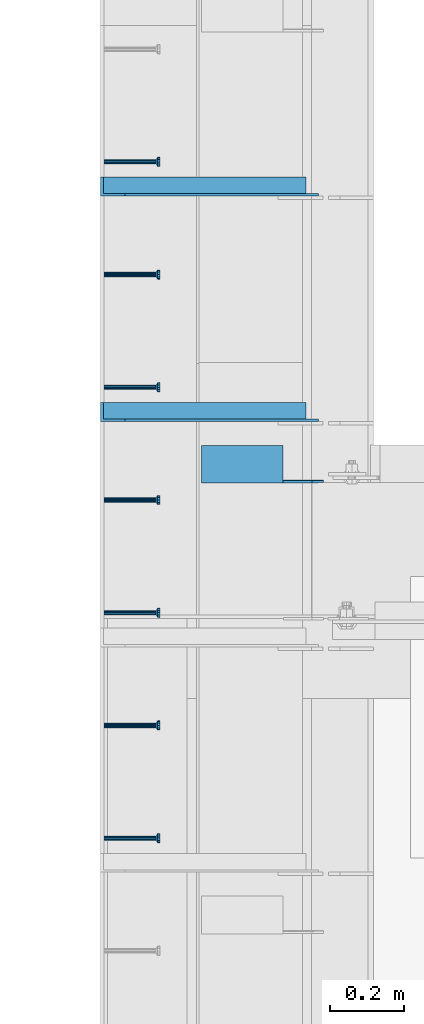
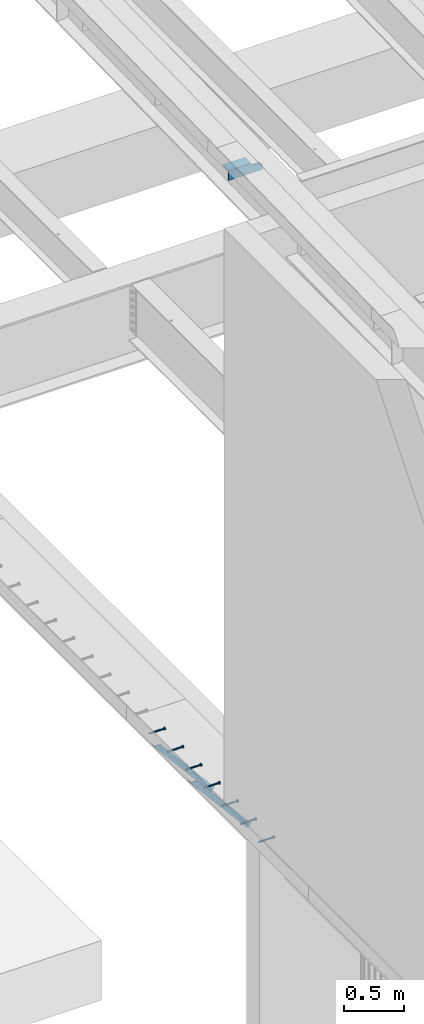
# One storey, part 1276 of 1763: 8 beams, 2 members, 9 elements without a shape of their own.
"""IFC2X3 building model written with IfcOpenShell, lengths in millimetres."""

from ifc_helpers import new_model, si_unit, frame, origin_with_axes, place, context, subcontext, project, spatial, faceted_brep, material, type_object, element, aggregate, save


model = new_model("IFC2X3")

# Units and contexts
model_context = context("Model", 3, precision=1e-05, world=origin_with_axes())
body_context = subcontext(model_context, "Body", "Model", "MODEL_VIEW")
ifc_project = project(units=[si_unit("LENGTHUNIT", "METRE", prefix="MILLI"), si_unit("AREAUNIT", "SQUARE_METRE"), si_unit("VOLUMEUNIT", "CUBIC_METRE"), si_unit("MASSUNIT", "GRAM", prefix="KILO"), si_unit("TIMEUNIT", "SECOND"), si_unit("PLANEANGLEUNIT", "RADIAN"), si_unit("SOLIDANGLEUNIT", "STERADIAN"), si_unit("THERMODYNAMICTEMPERATUREUNIT", "DEGREE_CELSIUS"), si_unit("LUMINOUSINTENSITYUNIT", "LUMEN")], contexts=[model_context])

# Site, building, storey
site_placement = place(None, origin_with_axes())
site = spatial("IfcSite", under=ifc_project, at=site_placement, CompositionType="ELEMENT")
building_placement = place(site_placement, origin_with_axes())
building = spatial("IfcBuilding", under=site, at=building_placement, Name="Undefined", CompositionType="ELEMENT")
storey_placement = place(building_placement, origin_with_axes())
storey = spatial("IfcBuildingStorey", under=building, at=storey_placement, Name="Undefined", CompositionType="ELEMENT", Elevation=0.0)

# Assembly, beam
assembly_1_placement = place(storey_placement, origin_with_axes())
assembly_1 = element("IfcElementAssembly", 1, at=assembly_1_placement, inside=storey, Name="HEADED STUD ANCHOR", AssemblyPlace="NOTDEFINED", PredefinedType="RIGID_FRAME")
ifc_material_1 = material(Name="STEEL/A108")
beam_type_1 = type_object("IfcBeamType", PredefinedType="NOTDEFINED")
beam_1_placement = place(assembly_1_placement, frame((-87975.5122736983, 36972.8750061035, 5268.91250001202), z_axis=(0.0, 0.0, -1.0), x_axis=(1.0, 0.0, 0.0)))
beam_1 = element("IfcBeam", 2, at=beam_1_placement, type_object=beam_type_1, material=ifc_material_1, Name="HEADED STUD ANCHOR", context=body_context, shape_type="Brep", body=[
    faceted_brep([(0.0, -3.1800000667572, 5.5), (0.0, -5.5, 3.1800000667572), (141.732000000002, -5.5, 3.1800000667572), (141.732000000002, -3.1800000667572, 5.5), (0.0, -6.34999999999491, 1.45519152283669e-11), (141.732000000002, -6.34999990463257, 0.0), (0.0, -5.5, -3.1800000667572), (141.732000000002, -5.5, -3.1800000667572), (0.0, -3.1800000667572, -5.5), (141.732000000002, -3.1800000667572, -5.5), (0.0, 0.0, -6.34999990463257), (141.732000000002, 0.0, -6.34999990463257), (0.0, 3.1800000667572, -5.5), (141.732000000002, 3.1800000667572, -5.5), (0.0, 5.5, -3.1800000667572), (141.732000000002, 5.5, -3.1800000667572), (0.0, 6.34999999999491, -2.91038304567337e-11), (141.732000000002, 6.34999990463257, 0.0), (0.0, 5.5, 3.1800000667572), (141.732000000002, 5.5, 3.1800000667572), (0.0, 3.1800000667572, 5.5), (141.732000000002, 3.1800000667572, 5.5), (0.0, 0.0, 6.34999990463257), (141.732000000002, 0.0, 6.34999990463257), (144.780000000001, -10.9899997711182, 6.34999990463257), (144.780000000001, -6.34000015258789, 10.9899997711182), (144.780000000001, -12.6999998092651, 0.0), (144.780000000001, -10.9899997711182, -6.34999990463257), (144.780000000001, -6.34000015258789, -10.9899997711182), (144.780000000001, 0.0, -12.6899995803833), (144.780000000001, 6.34000015258789, -10.9899997711182), (144.780000000001, 10.9899997711182, -6.34999990463257), (144.780000000001, 12.6999998092651, 0.0), (144.780000000001, 10.9899997711182, 6.34999990463257), (144.780000000001, 6.34000015258789, 10.9899997711182), (144.780000000001, 0.0, 12.6899995803833), (152.400000000001, -10.9899997711182, 6.34999990463257), (152.400000000001, -6.34000015258789, 10.9899997711182), (152.400000000001, -12.6999998092651, 0.0), (152.400000000001, -10.9899997711182, -6.34999990463257), (152.400000000001, -6.34000015258789, -10.9899997711182), (152.400000000001, 0.0, -12.6899995803833), (152.400000000001, 6.34000015258789, -10.9899997711182), (152.400000000001, 10.9899997711182, -6.34999990463257), (152.400000000001, 12.6999998092651, 0.0), (152.400000000001, 10.9899997711182, 6.34999990463257), (152.400000000001, 6.34000015258789, 10.9899997711182), (152.400000000001, 0.0, 12.6899995803833)], [[[0, 1, 2, 3]], [[1, 4, 5, 2]], [[4, 6, 7, 5]], [[6, 8, 9, 7]], [[8, 10, 11, 9]], [[10, 12, 13, 11]], [[12, 14, 15, 13]], [[14, 16, 17, 15]], [[16, 18, 19, 17]], [[18, 20, 21, 19]], [[20, 22, 23, 21]], [[22, 0, 3, 23]], [[22, 20, 18, 16, 14, 12, 10, 8, 6, 4, 1, 0]], [[3, 2, 24, 25]], [[2, 5, 26, 24]], [[5, 7, 27, 26]], [[7, 9, 28, 27]], [[9, 11, 29, 28]], [[11, 13, 30, 29]], [[13, 15, 31, 30]], [[15, 17, 32, 31]], [[17, 19, 33, 32]], [[19, 21, 34, 33]], [[21, 23, 35, 34]], [[23, 3, 25, 35]], [[25, 24, 36, 37]], [[24, 26, 38, 36]], [[26, 27, 39, 38]], [[27, 28, 40, 39]], [[28, 29, 41, 40]], [[29, 30, 42, 41]], [[30, 31, 43, 42]], [[31, 32, 44, 43]], [[32, 33, 45, 44]], [[33, 34, 46, 45]], [[34, 35, 47, 46]], [[35, 25, 37, 47]], [[38, 39, 40, 41, 42, 43, 44, 45, 46, 47, 37, 36]]]),
])
aggregate(assembly_1, [beam_1])

assembly_2_placement = place(storey_placement, origin_with_axes())
assembly_2 = element("IfcElementAssembly", 3, at=assembly_2_placement, inside=storey, Name="HEADED STUD ANCHOR", AssemblyPlace="NOTDEFINED", PredefinedType="RIGID_FRAME")
beam_2_placement = place(assembly_2_placement, frame((-87975.5122736983, 37277.6750061035, 5268.91250001202), z_axis=(0.0, 0.0, -1.0), x_axis=(1.0, 0.0, 0.0)))
beam_2 = element("IfcBeam", 4, at=beam_2_placement, type_object=beam_type_1, material=ifc_material_1, Name="HEADED STUD ANCHOR", context=body_context, shape_type="Brep", body=[
    faceted_brep([(0.0, -3.1800000667572, 5.5), (0.0, -5.5, 3.1800000667572), (141.732000000002, -5.5, 3.1800000667572), (141.732000000002, -3.1800000667572, 5.5), (0.0, -6.34999999999491, 1.45519152283669e-11), (141.732000000002, -6.34999990463257, 0.0), (0.0, -5.5, -3.1800000667572), (141.732000000002, -5.5, -3.1800000667572), (0.0, -3.1800000667572, -5.5), (141.732000000002, -3.1800000667572, -5.5), (0.0, 0.0, -6.34999990463257), (141.732000000002, 0.0, -6.34999990463257), (0.0, 3.1800000667572, -5.5), (141.732000000002, 3.1800000667572, -5.5), (0.0, 5.5, -3.1800000667572), (141.732000000002, 5.5, -3.1800000667572), (0.0, 6.34999999999491, -2.91038304567337e-11), (141.732000000002, 6.34999990463257, 0.0), (0.0, 5.5, 3.1800000667572), (141.732000000002, 5.5, 3.1800000667572), (0.0, 3.1800000667572, 5.5), (141.732000000002, 3.1800000667572, 5.5), (0.0, 0.0, 6.34999990463257), (141.732000000002, 0.0, 6.34999990463257), (144.780000000001, -10.9899997711182, 6.34999990463257), (144.780000000001, -6.34000015258789, 10.9899997711182), (144.780000000001, -12.6999998092651, 0.0), (144.780000000001, -10.9899997711182, -6.34999990463257), (144.780000000001, -6.34000015258789, -10.9899997711182), (144.780000000001, 0.0, -12.6899995803833), (144.780000000001, 6.34000015258789, -10.9899997711182), (144.780000000001, 10.9899997711182, -6.34999990463257), (144.780000000001, 12.6999998092651, 0.0), (144.780000000001, 10.9899997711182, 6.34999990463257), (144.780000000001, 6.34000015258789, 10.9899997711182), (144.780000000001, 0.0, 12.6899995803833), (152.400000000001, -10.9899997711182, 6.34999990463257), (152.400000000001, -6.34000015258789, 10.9899997711182), (152.400000000001, -12.6999998092651, 0.0), (152.400000000001, -10.9899997711182, -6.34999990463257), (152.400000000001, -6.34000015258789, -10.9899997711182), (152.400000000001, 0.0, -12.6899995803833), (152.400000000001, 6.34000015258789, -10.9899997711182), (152.400000000001, 10.9899997711182, -6.34999990463257), (152.400000000001, 12.6999998092651, 0.0), (152.400000000001, 10.9899997711182, 6.34999990463257), (152.400000000001, 6.34000015258789, 10.9899997711182), (152.400000000001, 0.0, 12.6899995803833)], [[[0, 1, 2, 3]], [[1, 4, 5, 2]], [[4, 6, 7, 5]], [[6, 8, 9, 7]], [[8, 10, 11, 9]], [[10, 12, 13, 11]], [[12, 14, 15, 13]], [[14, 16, 17, 15]], [[16, 18, 19, 17]], [[18, 20, 21, 19]], [[20, 22, 23, 21]], [[22, 0, 3, 23]], [[22, 20, 18, 16, 14, 12, 10, 8, 6, 4, 1, 0]], [[3, 2, 24, 25]], [[2, 5, 26, 24]], [[5, 7, 27, 26]], [[7, 9, 28, 27]], [[9, 11, 29, 28]], [[11, 13, 30, 29]], [[13, 15, 31, 30]], [[15, 17, 32, 31]], [[17, 19, 33, 32]], [[19, 21, 34, 33]], [[21, 23, 35, 34]], [[23, 3, 25, 35]], [[25, 24, 36, 37]], [[24, 26, 38, 36]], [[26, 27, 39, 38]], [[27, 28, 40, 39]], [[28, 29, 41, 40]], [[29, 30, 42, 41]], [[30, 31, 43, 42]], [[31, 32, 44, 43]], [[32, 33, 45, 44]], [[33, 34, 46, 45]], [[34, 35, 47, 46]], [[35, 25, 37, 47]], [[38, 39, 40, 41, 42, 43, 44, 45, 46, 47, 37, 36]]]),
])
aggregate(assembly_2, [beam_2])

assembly_3_placement = place(storey_placement, origin_with_axes())
assembly_3 = element("IfcElementAssembly", 5, at=assembly_3_placement, inside=storey, Name="HEADED STUD ANCHOR", AssemblyPlace="NOTDEFINED", PredefinedType="RIGID_FRAME")
beam_3_placement = place(assembly_3_placement, frame((-87975.5122736983, 37582.4750061035, 5268.91250001202), z_axis=(0.0, 0.0, -1.0), x_axis=(1.0, 0.0, 0.0)))
beam_3 = element("IfcBeam", 6, at=beam_3_placement, type_object=beam_type_1, material=ifc_material_1, Name="HEADED STUD ANCHOR", context=body_context, shape_type="Brep", body=[
    faceted_brep([(0.0, -3.1800000667572, 5.5), (0.0, -5.5, 3.1800000667572), (141.732000000002, -5.5, 3.1800000667572), (141.732000000002, -3.1800000667572, 5.5), (0.0, -6.34999999999491, 1.45519152283669e-11), (141.732000000002, -6.34999990463257, 0.0), (0.0, -5.5, -3.1800000667572), (141.732000000002, -5.5, -3.1800000667572), (0.0, -3.1800000667572, -5.5), (141.732000000002, -3.1800000667572, -5.5), (0.0, 0.0, -6.34999990463257), (141.732000000002, 0.0, -6.34999990463257), (0.0, 3.1800000667572, -5.5), (141.732000000002, 3.1800000667572, -5.5), (0.0, 5.5, -3.1800000667572), (141.732000000002, 5.5, -3.1800000667572), (0.0, 6.34999999999491, -2.91038304567337e-11), (141.732000000002, 6.34999990463257, 0.0), (0.0, 5.5, 3.1800000667572), (141.732000000002, 5.5, 3.1800000667572), (0.0, 3.1800000667572, 5.5), (141.732000000002, 3.1800000667572, 5.5), (0.0, 0.0, 6.34999990463257), (141.732000000002, 0.0, 6.34999990463257), (144.780000000001, -10.9899997711182, 6.34999990463257), (144.780000000001, -6.34000015258789, 10.9899997711182), (144.780000000001, -12.6999998092651, 0.0), (144.780000000001, -10.9899997711182, -6.34999990463257), (144.780000000001, -6.34000015258789, -10.9899997711182), (144.780000000001, 0.0, -12.6899995803833), (144.780000000001, 6.34000015258789, -10.9899997711182), (144.780000000001, 10.9899997711182, -6.34999990463257), (144.780000000001, 12.6999998092651, 0.0), (144.780000000001, 10.9899997711182, 6.34999990463257), (144.780000000001, 6.34000015258789, 10.9899997711182), (144.780000000001, 0.0, 12.6899995803833), (152.400000000001, -10.9899997711182, 6.34999990463257), (152.400000000001, -6.34000015258789, 10.9899997711182), (152.400000000001, -12.6999998092651, 0.0), (152.400000000001, -10.9899997711182, -6.34999990463257), (152.400000000001, -6.34000015258789, -10.9899997711182), (152.400000000001, 0.0, -12.6899995803833), (152.400000000001, 6.34000015258789, -10.9899997711182), (152.400000000001, 10.9899997711182, -6.34999990463257), (152.400000000001, 12.6999998092651, 0.0), (152.400000000001, 10.9899997711182, 6.34999990463257), (152.400000000001, 6.34000015258789, 10.9899997711182), (152.400000000001, 0.0, 12.6899995803833)], [[[0, 1, 2, 3]], [[1, 4, 5, 2]], [[4, 6, 7, 5]], [[6, 8, 9, 7]], [[8, 10, 11, 9]], [[10, 12, 13, 11]], [[12, 14, 15, 13]], [[14, 16, 17, 15]], [[16, 18, 19, 17]], [[18, 20, 21, 19]], [[20, 22, 23, 21]], [[22, 0, 3, 23]], [[22, 20, 18, 16, 14, 12, 10, 8, 6, 4, 1, 0]], [[3, 2, 24, 25]], [[2, 5, 26, 24]], [[5, 7, 27, 26]], [[7, 9, 28, 27]], [[9, 11, 29, 28]], [[11, 13, 30, 29]], [[13, 15, 31, 30]], [[15, 17, 32, 31]], [[17, 19, 33, 32]], [[19, 21, 34, 33]], [[21, 23, 35, 34]], [[23, 3, 25, 35]], [[25, 24, 36, 37]], [[24, 26, 38, 36]], [[26, 27, 39, 38]], [[27, 28, 40, 39]], [[28, 29, 41, 40]], [[29, 30, 42, 41]], [[30, 31, 43, 42]], [[31, 32, 44, 43]], [[32, 33, 45, 44]], [[33, 34, 46, 45]], [[34, 35, 47, 46]], [[35, 25, 37, 47]], [[38, 39, 40, 41, 42, 43, 44, 45, 46, 47, 37, 36]]]),
])
aggregate(assembly_3, [beam_3])

assembly_4_placement = place(storey_placement, origin_with_axes())
assembly_4 = element("IfcElementAssembly", 7, at=assembly_4_placement, inside=storey, Name="HEADED STUD ANCHOR", AssemblyPlace="NOTDEFINED", PredefinedType="RIGID_FRAME")
beam_4_placement = place(assembly_4_placement, frame((-87975.5122736983, 37887.2750061035, 5268.91250001202), z_axis=(0.0, 0.0, -1.0), x_axis=(1.0, 0.0, 0.0)))
beam_4 = element("IfcBeam", 8, at=beam_4_placement, type_object=beam_type_1, material=ifc_material_1, Name="HEADED STUD ANCHOR", context=body_context, shape_type="Brep", body=[
    faceted_brep([(0.0, -3.1800000667572, 5.5), (0.0, -5.5, 3.1800000667572), (141.732000000002, -5.5, 3.1800000667572), (141.732000000002, -3.1800000667572, 5.5), (0.0, -6.34999999999491, 1.45519152283669e-11), (141.732000000002, -6.34999990463257, 0.0), (0.0, -5.5, -3.1800000667572), (141.732000000002, -5.5, -3.1800000667572), (0.0, -3.1800000667572, -5.5), (141.732000000002, -3.1800000667572, -5.5), (0.0, 0.0, -6.34999990463257), (141.732000000002, 0.0, -6.34999990463257), (0.0, 3.1800000667572, -5.5), (141.732000000002, 3.1800000667572, -5.5), (0.0, 5.5, -3.1800000667572), (141.732000000002, 5.5, -3.1800000667572), (0.0, 6.34999999999491, -2.91038304567337e-11), (141.732000000002, 6.34999990463257, 0.0), (0.0, 5.5, 3.1800000667572), (141.732000000002, 5.5, 3.1800000667572), (0.0, 3.1800000667572, 5.5), (141.732000000002, 3.1800000667572, 5.5), (0.0, 0.0, 6.34999990463257), (141.732000000002, 0.0, 6.34999990463257), (144.780000000001, -10.9899997711182, 6.34999990463257), (144.780000000001, -6.34000015258789, 10.9899997711182), (144.780000000001, -12.6999998092651, 0.0), (144.780000000001, -10.9899997711182, -6.34999990463257), (144.780000000001, -6.34000015258789, -10.9899997711182), (144.780000000001, 0.0, -12.6899995803833), (144.780000000001, 6.34000015258789, -10.9899997711182), (144.780000000001, 10.9899997711182, -6.34999990463257), (144.780000000001, 12.6999998092651, 0.0), (144.780000000001, 10.9899997711182, 6.34999990463257), (144.780000000001, 6.34000015258789, 10.9899997711182), (144.780000000001, 0.0, 12.6899995803833), (152.400000000001, -10.9899997711182, 6.34999990463257), (152.400000000001, -6.34000015258789, 10.9899997711182), (152.400000000001, -12.6999998092651, 0.0), (152.400000000001, -10.9899997711182, -6.34999990463257), (152.400000000001, -6.34000015258789, -10.9899997711182), (152.400000000001, 0.0, -12.6899995803833), (152.400000000001, 6.34000015258789, -10.9899997711182), (152.400000000001, 10.9899997711182, -6.34999990463257), (152.400000000001, 12.6999998092651, 0.0), (152.400000000001, 10.9899997711182, 6.34999990463257), (152.400000000001, 6.34000015258789, 10.9899997711182), (152.400000000001, 0.0, 12.6899995803833)], [[[0, 1, 2, 3]], [[1, 4, 5, 2]], [[4, 6, 7, 5]], [[6, 8, 9, 7]], [[8, 10, 11, 9]], [[10, 12, 13, 11]], [[12, 14, 15, 13]], [[14, 16, 17, 15]], [[16, 18, 19, 17]], [[18, 20, 21, 19]], [[20, 22, 23, 21]], [[22, 0, 3, 23]], [[22, 20, 18, 16, 14, 12, 10, 8, 6, 4, 1, 0]], [[3, 2, 24, 25]], [[2, 5, 26, 24]], [[5, 7, 27, 26]], [[7, 9, 28, 27]], [[9, 11, 29, 28]], [[11, 13, 30, 29]], [[13, 15, 31, 30]], [[15, 17, 32, 31]], [[17, 19, 33, 32]], [[19, 21, 34, 33]], [[21, 23, 35, 34]], [[23, 3, 25, 35]], [[25, 24, 36, 37]], [[24, 26, 38, 36]], [[26, 27, 39, 38]], [[27, 28, 40, 39]], [[28, 29, 41, 40]], [[29, 30, 42, 41]], [[30, 31, 43, 42]], [[31, 32, 44, 43]], [[32, 33, 45, 44]], [[33, 34, 46, 45]], [[34, 35, 47, 46]], [[35, 25, 37, 47]], [[38, 39, 40, 41, 42, 43, 44, 45, 46, 47, 37, 36]]]),
])
aggregate(assembly_4, [beam_4])

assembly_5_placement = place(storey_placement, origin_with_axes())
assembly_5 = element("IfcElementAssembly", 9, at=assembly_5_placement, inside=storey, Name="HEADED STUD ANCHOR", AssemblyPlace="NOTDEFINED", PredefinedType="RIGID_FRAME")
beam_5_placement = place(assembly_5_placement, frame((-87975.5122736983, 38192.0750061035, 5268.91250001202), z_axis=(0.0, 0.0, -1.0), x_axis=(1.0, 0.0, 0.0)))
beam_5 = element("IfcBeam", 10, at=beam_5_placement, type_object=beam_type_1, material=ifc_material_1, Name="HEADED STUD ANCHOR", context=body_context, shape_type="Brep", body=[
    faceted_brep([(0.0, -3.1800000667572, 5.5), (0.0, -5.5, 3.1800000667572), (141.732000000002, -5.5, 3.1800000667572), (141.732000000002, -3.1800000667572, 5.5), (0.0, -6.34999999999491, 1.45519152283669e-11), (141.732000000002, -6.34999990463257, 0.0), (0.0, -5.5, -3.1800000667572), (141.732000000002, -5.5, -3.1800000667572), (0.0, -3.1800000667572, -5.5), (141.732000000002, -3.1800000667572, -5.5), (0.0, 0.0, -6.34999990463257), (141.732000000002, 0.0, -6.34999990463257), (0.0, 3.1800000667572, -5.5), (141.732000000002, 3.1800000667572, -5.5), (0.0, 5.5, -3.1800000667572), (141.732000000002, 5.5, -3.1800000667572), (0.0, 6.34999999999491, -2.91038304567337e-11), (141.732000000002, 6.34999990463257, 0.0), (0.0, 5.5, 3.1800000667572), (141.732000000002, 5.5, 3.1800000667572), (0.0, 3.1800000667572, 5.5), (141.732000000002, 3.1800000667572, 5.5), (0.0, 0.0, 6.34999990463257), (141.732000000002, 0.0, 6.34999990463257), (144.780000000001, -10.9899997711182, 6.34999990463257), (144.780000000001, -6.34000015258789, 10.9899997711182), (144.780000000001, -12.6999998092651, 0.0), (144.780000000001, -10.9899997711182, -6.34999990463257), (144.780000000001, -6.34000015258789, -10.9899997711182), (144.780000000001, 0.0, -12.6899995803833), (144.780000000001, 6.34000015258789, -10.9899997711182), (144.780000000001, 10.9899997711182, -6.34999990463257), (144.780000000001, 12.6999998092651, 0.0), (144.780000000001, 10.9899997711182, 6.34999990463257), (144.780000000001, 6.34000015258789, 10.9899997711182), (144.780000000001, 0.0, 12.6899995803833), (152.400000000001, -10.9899997711182, 6.34999990463257), (152.400000000001, -6.34000015258789, 10.9899997711182), (152.400000000001, -12.6999998092651, 0.0), (152.400000000001, -10.9899997711182, -6.34999990463257), (152.400000000001, -6.34000015258789, -10.9899997711182), (152.400000000001, 0.0, -12.6899995803833), (152.400000000001, 6.34000015258789, -10.9899997711182), (152.400000000001, 10.9899997711182, -6.34999990463257), (152.400000000001, 12.6999998092651, 0.0), (152.400000000001, 10.9899997711182, 6.34999990463257), (152.400000000001, 6.34000015258789, 10.9899997711182), (152.400000000001, 0.0, 12.6899995803833)], [[[0, 1, 2, 3]], [[1, 4, 5, 2]], [[4, 6, 7, 5]], [[6, 8, 9, 7]], [[8, 10, 11, 9]], [[10, 12, 13, 11]], [[12, 14, 15, 13]], [[14, 16, 17, 15]], [[16, 18, 19, 17]], [[18, 20, 21, 19]], [[20, 22, 23, 21]], [[22, 0, 3, 23]], [[22, 20, 18, 16, 14, 12, 10, 8, 6, 4, 1, 0]], [[3, 2, 24, 25]], [[2, 5, 26, 24]], [[5, 7, 27, 26]], [[7, 9, 28, 27]], [[9, 11, 29, 28]], [[11, 13, 30, 29]], [[13, 15, 31, 30]], [[15, 17, 32, 31]], [[17, 19, 33, 32]], [[19, 21, 34, 33]], [[21, 23, 35, 34]], [[23, 3, 25, 35]], [[25, 24, 36, 37]], [[24, 26, 38, 36]], [[26, 27, 39, 38]], [[27, 28, 40, 39]], [[28, 29, 41, 40]], [[29, 30, 42, 41]], [[30, 31, 43, 42]], [[31, 32, 44, 43]], [[32, 33, 45, 44]], [[33, 34, 46, 45]], [[34, 35, 47, 46]], [[35, 25, 37, 47]], [[38, 39, 40, 41, 42, 43, 44, 45, 46, 47, 37, 36]]]),
])
aggregate(assembly_5, [beam_5])

assembly_6_placement = place(storey_placement, origin_with_axes())
assembly_6 = element("IfcElementAssembly", 11, at=assembly_6_placement, inside=storey, Name="HEADED STUD ANCHOR", AssemblyPlace="NOTDEFINED", PredefinedType="RIGID_FRAME")
beam_6_placement = place(assembly_6_placement, frame((-87975.5122736983, 38496.8750061035, 5268.91250001202), z_axis=(0.0, 0.0, -1.0), x_axis=(1.0, 0.0, 0.0)))
beam_6 = element("IfcBeam", 12, at=beam_6_placement, type_object=beam_type_1, material=ifc_material_1, Name="HEADED STUD ANCHOR", context=body_context, shape_type="Brep", body=[
    faceted_brep([(0.0, -3.1800000667572, 5.5), (0.0, -5.5, 3.1800000667572), (141.732000000002, -5.5, 3.1800000667572), (141.732000000002, -3.1800000667572, 5.5), (0.0, -6.34999999999491, 1.45519152283669e-11), (141.732000000002, -6.34999990463257, 0.0), (0.0, -5.5, -3.1800000667572), (141.732000000002, -5.5, -3.1800000667572), (0.0, -3.1800000667572, -5.5), (141.732000000002, -3.1800000667572, -5.5), (0.0, 0.0, -6.34999990463257), (141.732000000002, 0.0, -6.34999990463257), (0.0, 3.1800000667572, -5.5), (141.732000000002, 3.1800000667572, -5.5), (0.0, 5.5, -3.1800000667572), (141.732000000002, 5.5, -3.1800000667572), (0.0, 6.34999999999491, -2.91038304567337e-11), (141.732000000002, 6.34999990463257, 0.0), (0.0, 5.5, 3.1800000667572), (141.732000000002, 5.5, 3.1800000667572), (0.0, 3.1800000667572, 5.5), (141.732000000002, 3.1800000667572, 5.5), (0.0, 0.0, 6.34999990463257), (141.732000000002, 0.0, 6.34999990463257), (144.780000000001, -10.9899997711182, 6.34999990463257), (144.780000000001, -6.34000015258789, 10.9899997711182), (144.780000000001, -12.6999998092651, 0.0), (144.780000000001, -10.9899997711182, -6.34999990463257), (144.780000000001, -6.34000015258789, -10.9899997711182), (144.780000000001, 0.0, -12.6899995803833), (144.780000000001, 6.34000015258789, -10.9899997711182), (144.780000000001, 10.9899997711182, -6.34999990463257), (144.780000000001, 12.6999998092651, 0.0), (144.780000000001, 10.9899997711182, 6.34999990463257), (144.780000000001, 6.34000015258789, 10.9899997711182), (144.780000000001, 0.0, 12.6899995803833), (152.400000000001, -10.9899997711182, 6.34999990463257), (152.400000000001, -6.34000015258789, 10.9899997711182), (152.400000000001, -12.6999998092651, 0.0), (152.400000000001, -10.9899997711182, -6.34999990463257), (152.400000000001, -6.34000015258789, -10.9899997711182), (152.400000000001, 0.0, -12.6899995803833), (152.400000000001, 6.34000015258789, -10.9899997711182), (152.400000000001, 10.9899997711182, -6.34999990463257), (152.400000000001, 12.6999998092651, 0.0), (152.400000000001, 10.9899997711182, 6.34999990463257), (152.400000000001, 6.34000015258789, 10.9899997711182), (152.400000000001, 0.0, 12.6899995803833)], [[[0, 1, 2, 3]], [[1, 4, 5, 2]], [[4, 6, 7, 5]], [[6, 8, 9, 7]], [[8, 10, 11, 9]], [[10, 12, 13, 11]], [[12, 14, 15, 13]], [[14, 16, 17, 15]], [[16, 18, 19, 17]], [[18, 20, 21, 19]], [[20, 22, 23, 21]], [[22, 0, 3, 23]], [[22, 20, 18, 16, 14, 12, 10, 8, 6, 4, 1, 0]], [[3, 2, 24, 25]], [[2, 5, 26, 24]], [[5, 7, 27, 26]], [[7, 9, 28, 27]], [[9, 11, 29, 28]], [[11, 13, 30, 29]], [[13, 15, 31, 30]], [[15, 17, 32, 31]], [[17, 19, 33, 32]], [[19, 21, 34, 33]], [[21, 23, 35, 34]], [[23, 3, 25, 35]], [[25, 24, 36, 37]], [[24, 26, 38, 36]], [[26, 27, 39, 38]], [[27, 28, 40, 39]], [[28, 29, 41, 40]], [[29, 30, 42, 41]], [[30, 31, 43, 42]], [[31, 32, 44, 43]], [[32, 33, 45, 44]], [[33, 34, 46, 45]], [[34, 35, 47, 46]], [[35, 25, 37, 47]], [[38, 39, 40, 41, 42, 43, 44, 45, 46, 47, 37, 36]]]),
])
aggregate(assembly_6, [beam_6])

assembly_7_placement = place(storey_placement, origin_with_axes())
assembly_7 = element("IfcElementAssembly", 13, at=assembly_7_placement, inside=storey, Name="HEADED STUD ANCHOR", AssemblyPlace="NOTDEFINED", PredefinedType="RIGID_FRAME")
beam_7_placement = place(assembly_7_placement, frame((-87975.5122736983, 38801.6750061035, 5268.91250001202), z_axis=(0.0, 0.0, -1.0), x_axis=(1.0, 0.0, 0.0)))
beam_7 = element("IfcBeam", 14, at=beam_7_placement, type_object=beam_type_1, material=ifc_material_1, Name="HEADED STUD ANCHOR", context=body_context, shape_type="Brep", body=[
    faceted_brep([(0.0, -3.1800000667572, 5.5), (0.0, -5.5, 3.1800000667572), (141.732000000002, -5.5, 3.1800000667572), (141.732000000002, -3.1800000667572, 5.5), (0.0, -6.34999999999491, 1.45519152283669e-11), (141.732000000002, -6.34999990463257, 0.0), (0.0, -5.5, -3.1800000667572), (141.732000000002, -5.5, -3.1800000667572), (0.0, -3.1800000667572, -5.5), (141.732000000002, -3.1800000667572, -5.5), (0.0, 0.0, -6.34999990463257), (141.732000000002, 0.0, -6.34999990463257), (0.0, 3.1800000667572, -5.5), (141.732000000002, 3.1800000667572, -5.5), (0.0, 5.5, -3.1800000667572), (141.732000000002, 5.5, -3.1800000667572), (0.0, 6.34999999999491, -2.91038304567337e-11), (141.732000000002, 6.34999990463257, 0.0), (0.0, 5.5, 3.1800000667572), (141.732000000002, 5.5, 3.1800000667572), (0.0, 3.1800000667572, 5.5), (141.732000000002, 3.1800000667572, 5.5), (0.0, 0.0, 6.34999990463257), (141.732000000002, 0.0, 6.34999990463257), (144.780000000001, -10.9899997711182, 6.34999990463257), (144.780000000001, -6.34000015258789, 10.9899997711182), (144.780000000001, -12.6999998092651, 0.0), (144.780000000001, -10.9899997711182, -6.34999990463257), (144.780000000001, -6.34000015258789, -10.9899997711182), (144.780000000001, 0.0, -12.6899995803833), (144.780000000001, 6.34000015258789, -10.9899997711182), (144.780000000001, 10.9899997711182, -6.34999990463257), (144.780000000001, 12.6999998092651, 0.0), (144.780000000001, 10.9899997711182, 6.34999990463257), (144.780000000001, 6.34000015258789, 10.9899997711182), (144.780000000001, 0.0, 12.6899995803833), (152.400000000001, -10.9899997711182, 6.34999990463257), (152.400000000001, -6.34000015258789, 10.9899997711182), (152.400000000001, -12.6999998092651, 0.0), (152.400000000001, -10.9899997711182, -6.34999990463257), (152.400000000001, -6.34000015258789, -10.9899997711182), (152.400000000001, 0.0, -12.6899995803833), (152.400000000001, 6.34000015258789, -10.9899997711182), (152.400000000001, 10.9899997711182, -6.34999990463257), (152.400000000001, 12.6999998092651, 0.0), (152.400000000001, 10.9899997711182, 6.34999990463257), (152.400000000001, 6.34000015258789, 10.9899997711182), (152.400000000001, 0.0, 12.6899995803833)], [[[0, 1, 2, 3]], [[1, 4, 5, 2]], [[4, 6, 7, 5]], [[6, 8, 9, 7]], [[8, 10, 11, 9]], [[10, 12, 13, 11]], [[12, 14, 15, 13]], [[14, 16, 17, 15]], [[16, 18, 19, 17]], [[18, 20, 21, 19]], [[20, 22, 23, 21]], [[22, 0, 3, 23]], [[22, 20, 18, 16, 14, 12, 10, 8, 6, 4, 1, 0]], [[3, 2, 24, 25]], [[2, 5, 26, 24]], [[5, 7, 27, 26]], [[7, 9, 28, 27]], [[9, 11, 29, 28]], [[11, 13, 30, 29]], [[13, 15, 31, 30]], [[15, 17, 32, 31]], [[17, 19, 33, 32]], [[19, 21, 34, 33]], [[21, 23, 35, 34]], [[23, 3, 25, 35]], [[25, 24, 36, 37]], [[24, 26, 38, 36]], [[26, 27, 39, 38]], [[27, 28, 40, 39]], [[28, 29, 41, 40]], [[29, 30, 42, 41]], [[30, 31, 43, 42]], [[31, 32, 44, 43]], [[32, 33, 45, 44]], [[33, 34, 46, 45]], [[34, 35, 47, 46]], [[35, 25, 37, 47]], [[38, 39, 40, 41, 42, 43, 44, 45, 46, 47, 37, 36]]]),
])
aggregate(assembly_7, [beam_7])

# Assembly, members
assembly_8_placement = place(storey_placement, origin_with_axes())
assembly_8 = element("IfcElementAssembly", 15, at=assembly_8_placement, inside=storey, Name="BEAM", AssemblyPlace="NOTDEFINED", PredefinedType="RIGID_FRAME")
ifc_material_2 = material(Name="STEEL/A36")
member_type = type_object("IfcMemberType", Name="L2X2X1/4", PredefinedType="NOTDEFINED")
member_1_placement = place(assembly_8_placement, frame((-87414.1929584935, 38735.0, 4557.35349338836), z_axis=(0.764183480307171, 0.0, 0.644998921259268), x_axis=(-0.644998921259266, 0.0, 0.764183480307173)))
member_1 = element("IfcMember", 16, at=member_1_placement, type_object=member_type, material=ifc_material_2, Name="ANGLE", ObjectType="L2X2X1/4", context=body_context, shape_type="Brep", body=[
    faceted_brep([(-1.45519152283669e-11, 25.4000000000015, -25.3999999999869), (1.45519152283669e-11, 25.4000000000015, 25.3999999999796), (812.060911532491, 25.4000000000015, 25.400000001966), (854.937976763787, 25.4000000000015, -25.3999999979424), (1.45519152283669e-11, 19.0499999999993, 25.3999999999796), (812.060911532491, 19.0500000000029, 25.400000001966), (-7.27595761418343e-12, 19.0499999999993, -19.0499999999956), (849.578343609872, 19.0500000000029, -19.0499999979511), (-7.27595761418343e-12, -25.4000000000015, -19.0499999999956), (849.578343609872, -25.4000000000015, -19.0499999979511), (-1.45519152283669e-11, -25.4000000000015, -25.3999999999869), (854.937976763787, -25.4000000000015, -25.3999999979424)], [[[0, 1, 2, 3]], [[1, 4, 5, 2]], [[4, 6, 7, 5]], [[6, 8, 9, 7]], [[8, 10, 11, 9]], [[10, 0, 3, 11]], [[5, 7, 9, 11, 3, 2]], [[10, 8, 6, 4, 1, 0]]]),
])
member_2_placement = place(assembly_8_placement, frame((-87414.1929584935, 38125.4, 4557.35349338836), z_axis=(0.764183480307171, 0.0, 0.644998921259268), x_axis=(-0.644998921259266, 0.0, 0.764183480307173)))
member_2 = element("IfcMember", 17, at=member_2_placement, type_object=member_type, material=ifc_material_2, Name="ANGLE", ObjectType="L2X2X1/4", context=body_context, shape_type="Brep", body=[
    faceted_brep([(-1.45519152283669e-11, 25.4000000000015, -25.3999999999869), (1.45519152283669e-11, 25.4000000000015, 25.3999999999796), (812.060911532491, 25.4000000000015, 25.400000001966), (854.937976763787, 25.4000000000015, -25.3999999979424), (1.45519152283669e-11, 19.0499999999993, 25.3999999999796), (812.060911532491, 19.0500000000029, 25.400000001966), (-7.27595761418343e-12, 19.0499999999993, -19.0499999999956), (849.578343609872, 19.0500000000029, -19.0499999979511), (-7.27595761418343e-12, -25.4000000000015, -19.0499999999956), (849.578343609872, -25.4000000000015, -19.0499999979511), (-1.45519152283669e-11, -25.4000000000015, -25.3999999999869), (854.937976763787, -25.4000000000015, -25.3999999979424)], [[[0, 1, 2, 3]], [[1, 4, 5, 2]], [[4, 6, 7, 5]], [[6, 8, 9, 7]], [[8, 10, 11, 9]], [[10, 0, 3, 11]], [[5, 7, 9, 11, 3, 2]], [[10, 8, 6, 4, 1, 0]]]),
])
aggregate(assembly_8, [member_1, member_2])

# Assembly, beam
assembly_9_placement = place(storey_placement, origin_with_axes())
assembly_9 = element("IfcElementAssembly", 18, at=assembly_9_placement, inside=storey, Name="BEAM", AssemblyPlace="NOTDEFINED", PredefinedType="RIGID_FRAME")
beam_type_2 = type_object("IfcBeamType", Name="L4X4X1/4", PredefinedType="NOTDEFINED")
beam_8_placement = place(assembly_9_placement, frame((-87711.9872706466, 37985.0719931941, 11404.2257873477), z_axis=(0.0, 0.0206852279954837, -0.999786037781472), x_axis=(1.0, 0.0, 0.0)))
beam_8 = element("IfcBeam", 19, at=beam_8_placement, type_object=beam_type_2, material=ifc_material_2, Name="BRACE", ObjectType="L4X4X1/4", context=body_context, shape_type="Brep", body=[
    faceted_brep([(220.662761923406, 44.4500000001208, -44.4499999999807), (220.662761962012, -50.800000000163, -44.4499999999553), (220.66276795695, -50.800000000163, -50.7999999999502), (220.662767915564, 50.8000000001339, -50.7999999999774), (220.662751535681, 50.8000000001339, -33.3786578752915), (220.662751538272, 44.4500000001208, -33.3786578752897), (299.243730570859, 44.4500000001135, -33.3375021376705), (299.243730570859, 50.8000000001339, -33.3375021376723), (2.11002770811319e-10, -50.8000000000357, -50.799999999952), (1.96450855582952e-10, -50.8000000000338, -44.4499999999534), (-2.18278728425503e-11, 44.4500000000007, -44.450000000048), (-1.81898940354586e-10, 44.4500000000371, 50.7999999999374), (-1.96450855582952e-10, 50.8000000000393, 50.7999999999374), (-3.63797880709171e-11, 50.8000000000011, -50.8000000000538), (330.993731689443, 44.4500000000007, 50.7999999999993), (330.993731689443, 50.7999999999993, 50.7999999999993), (330.993730570859, 44.4500000001281, -1.58750213774329), (330.993746948254, 50.8000000001412, -1.5875021377451)], [[[0, 1, 2, 3, 4, 5]], [[6, 5, 4, 7]], [[8, 9, 10, 11, 12, 13]], [[12, 11, 14, 15]], [[15, 14, 16, 17]], [[17, 16, 6, 7]], [[3, 13, 12, 15, 17, 7, 4]], [[8, 13, 3, 2]], [[9, 8, 2, 1]], [[10, 9, 1, 0]], [[16, 14, 11, 10, 0, 5, 6]]]),
])
aggregate(assembly_9, [beam_8])

save(model, "model.ifc")
